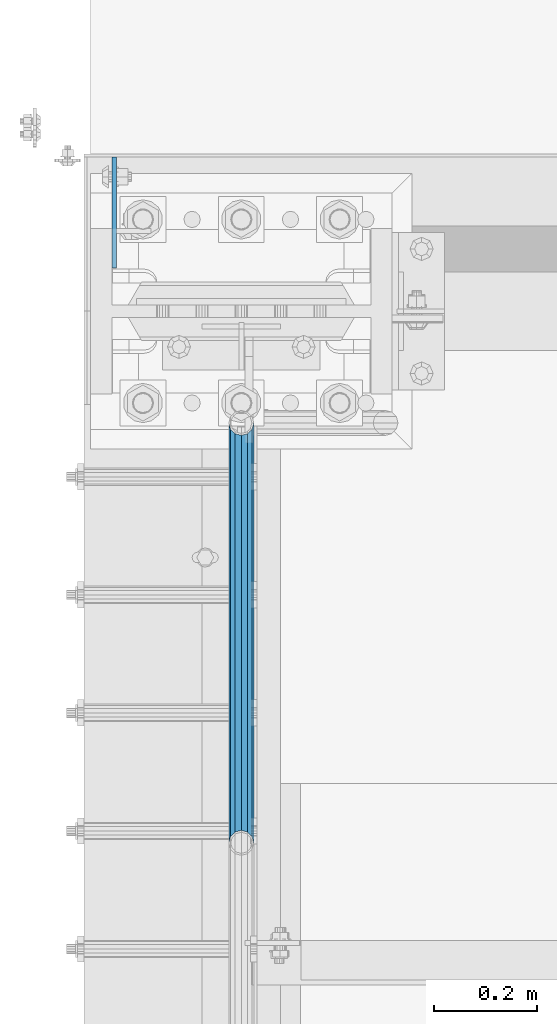
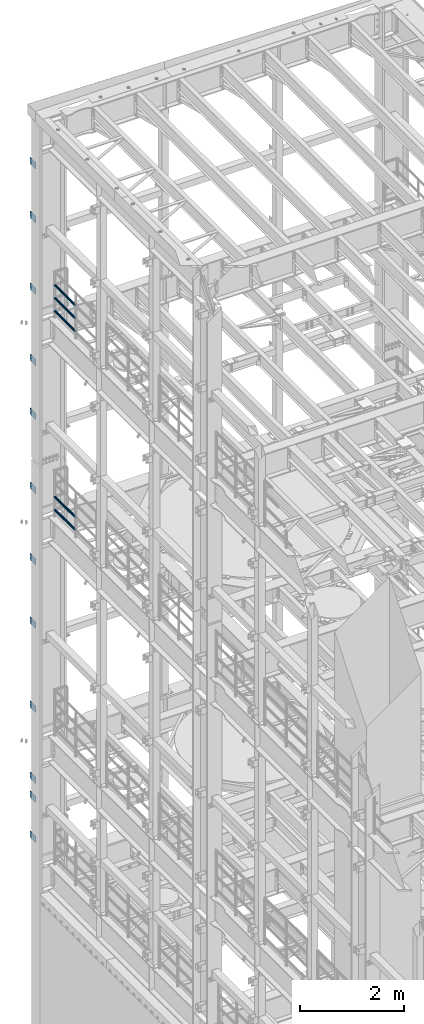
# One storey, part 1315 of 1876: 17 beams, 4 elements without a shape of their own.
"""IFC2X3 building model written with IfcOpenShell, lengths in millimetres."""

from ifc_helpers import new_model, si_unit, frame, origin_with_axes, place, context, subcontext, project, spatial, faceted_brep, material, type_object, element, aggregate, save


model = new_model("IFC2X3")

# Units and contexts
model_context = context("Model", 3, precision=1e-05, world=origin_with_axes())
body_context = subcontext(model_context, "Body", "Model", "MODEL_VIEW")
ifc_project = project(units=[si_unit("LENGTHUNIT", "METRE", prefix="MILLI"), si_unit("AREAUNIT", "SQUARE_METRE"), si_unit("VOLUMEUNIT", "CUBIC_METRE"), si_unit("MASSUNIT", "GRAM", prefix="KILO"), si_unit("TIMEUNIT", "SECOND"), si_unit("PLANEANGLEUNIT", "RADIAN"), si_unit("SOLIDANGLEUNIT", "STERADIAN"), si_unit("THERMODYNAMICTEMPERATUREUNIT", "DEGREE_CELSIUS"), si_unit("LUMINOUSINTENSITYUNIT", "LUMEN")], contexts=[model_context])

# Site, building, storey
site_placement = place(None, origin_with_axes())
site = spatial("IfcSite", under=ifc_project, at=site_placement, CompositionType="ELEMENT")
building_placement = place(site_placement, origin_with_axes())
building = spatial("IfcBuilding", under=site, at=building_placement, Name="Undefined", CompositionType="ELEMENT")
storey_placement = place(building_placement, origin_with_axes())
storey = spatial("IfcBuildingStorey", under=building, at=storey_placement, Name="Undefined", CompositionType="ELEMENT", Elevation=0.0)

# Assembly, beams
assembly_1_placement = place(storey_placement, origin_with_axes())
assembly_1 = element("IfcElementAssembly", 1, at=assembly_1_placement, inside=storey, Name="COLUMN", AssemblyPlace="NOTDEFINED", PredefinedType="RIGID_FRAME")
ifc_material_1 = material(Name="STEEL/A36")
beam_type_1 = type_object("IfcBeamType", PredefinedType="NOTDEFINED")
beam_1_placement = place(assembly_1_placement, frame((-246.0625, 13800.1375001356, 21450.3), z_axis=(0.0, 0.0, -1.0), x_axis=(0.0, 1.0, 0.0)))
beam_1 = element("IfcBeam", 2, at=beam_1_placement, type_object=beam_type_1, material=ifc_material_1, Name="PLATE", context=body_context, shape_type="Brep", body=[
    faceted_brep([(0.0, 4.76249999999982, -76.1999999999998), (3.63797880709171e-12, 4.76249999999982, 76.1999969482422), (214.312499998445, 4.76249999993797, 76.2000000000007), (214.312499998445, 4.76249999993797, -76.2000000000007), (3.63797880709171e-12, -4.76249999999982, 76.1999969482422), (214.312499998441, -4.76250000006257, 76.2000000000007), (0.0, -4.76249999999982, -76.1999999999998), (214.312499998441, -4.76250000006257, -76.2000000000007)], [[[0, 1, 2, 3]], [[1, 4, 5, 2]], [[4, 6, 7, 5]], [[6, 0, 3, 7]], [[5, 7, 3, 2]], [[6, 4, 1, 0]]]),
])
beam_2_placement = place(assembly_1_placement, frame((-246.0625, 13800.1375001356, 20186.65), z_axis=(0.0, 0.0, -1.0), x_axis=(0.0, 1.0, 0.0)))
beam_2 = element("IfcBeam", 3, at=beam_2_placement, type_object=beam_type_1, material=ifc_material_1, Name="PLATE", context=body_context, shape_type="Brep", body=[
    faceted_brep([(0.0, 4.76249999999982, -76.1999999999998), (3.63797880709171e-12, 4.76249999999982, 76.1999969482422), (214.312499998445, 4.76249999993797, 76.2000000000007), (214.312499998445, 4.76249999993797, -76.2000000000007), (3.63797880709171e-12, -4.76249999999982, 76.1999969482422), (214.312499998441, -4.76250000006257, 76.2000000000007), (0.0, -4.76249999999982, -76.1999999999998), (214.312499998441, -4.76250000006257, -76.2000000000007)], [[[0, 1, 2, 3]], [[1, 4, 5, 2]], [[4, 6, 7, 5]], [[6, 0, 3, 7]], [[5, 7, 3, 2]], [[6, 4, 1, 0]]]),
])
beam_3_placement = place(assembly_1_placement, frame((-246.0625, 13800.1375001356, 18503.9), z_axis=(0.0, 0.0, -1.0), x_axis=(0.0, 1.0, 0.0)))
beam_3 = element("IfcBeam", 4, at=beam_3_placement, type_object=beam_type_1, material=ifc_material_1, Name="PLATE", context=body_context, shape_type="Brep", body=[
    faceted_brep([(0.0, 4.76249999999982, -76.1999999999998), (3.63797880709171e-12, 4.76249999999982, 76.1999969482422), (214.312499998445, 4.76249999993797, 76.2000000000007), (214.312499998445, 4.76249999993797, -76.2000000000007), (3.63797880709171e-12, -4.76249999999982, 76.1999969482422), (214.312499998441, -4.76250000006257, 76.2000000000007), (0.0, -4.76249999999982, -76.1999999999998), (214.312499998441, -4.76250000006257, -76.2000000000007)], [[[0, 1, 2, 3]], [[1, 4, 5, 2]], [[4, 6, 7, 5]], [[6, 0, 3, 7]], [[5, 7, 3, 2]], [[6, 4, 1, 0]]]),
])
beam_4_placement = place(assembly_1_placement, frame((-246.0625, 13800.1375001356, 16827.5), z_axis=(0.0, 0.0, -1.0), x_axis=(0.0, 1.0, 0.0)))
beam_4 = element("IfcBeam", 5, at=beam_4_placement, type_object=beam_type_1, material=ifc_material_1, Name="PLATE", context=body_context, shape_type="Brep", body=[
    faceted_brep([(0.0, 4.76249999999982, -76.1999999999998), (3.63797880709171e-12, 4.76249999999982, 76.1999969482422), (214.312499998445, 4.76249999993797, 76.2000000000007), (214.312499998445, 4.76249999993797, -76.2000000000007), (3.63797880709171e-12, -4.76249999999982, 76.1999969482422), (214.312499998441, -4.76250000006257, 76.2000000000007), (0.0, -4.76249999999982, -76.1999999999998), (214.312499998441, -4.76250000006257, -76.2000000000007)], [[[0, 1, 2, 3]], [[1, 4, 5, 2]], [[4, 6, 7, 5]], [[6, 0, 3, 7]], [[5, 7, 3, 2]], [[6, 4, 1, 0]]]),
])
beam_5_placement = place(assembly_1_placement, frame((-246.0625, 13800.1375001356, 15563.85), z_axis=(0.0, 0.0, -1.0), x_axis=(0.0, 1.0, 0.0)))
beam_5 = element("IfcBeam", 6, at=beam_5_placement, type_object=beam_type_1, material=ifc_material_1, Name="PLATE", context=body_context, shape_type="Brep", body=[
    faceted_brep([(0.0, 4.76249999999982, -76.1999999999998), (3.63797880709171e-12, 4.76249999999982, 76.1999969482422), (214.312499998445, 4.76249999993797, 76.2000000000007), (214.312499998445, 4.76249999993797, -76.2000000000007), (3.63797880709171e-12, -4.76249999999982, 76.1999969482422), (214.312499998441, -4.76250000006257, 76.2000000000007), (0.0, -4.76249999999982, -76.1999999999998), (214.312499998441, -4.76250000006257, -76.2000000000007)], [[[0, 1, 2, 3]], [[1, 4, 5, 2]], [[4, 6, 7, 5]], [[6, 0, 3, 7]], [[5, 7, 3, 2]], [[6, 4, 1, 0]]]),
])
aggregate(assembly_1, [beam_1, beam_2, beam_3, beam_4, beam_5])

assembly_2_placement = place(storey_placement, origin_with_axes())
assembly_2 = element("IfcElementAssembly", 7, at=assembly_2_placement, inside=storey, Name="COLUMN", AssemblyPlace="NOTDEFINED", PredefinedType="RIGID_FRAME")
beam_6_placement = place(assembly_2_placement, frame((-246.0625, 13800.1375001356, 13817.6), z_axis=(0.0, 0.0, -1.0), x_axis=(0.0, 1.0, 0.0)))
beam_6 = element("IfcBeam", 8, at=beam_6_placement, type_object=beam_type_1, material=ifc_material_1, Name="PLATE", context=body_context, shape_type="Brep", body=[
    faceted_brep([(0.0, 4.76249999999982, -76.1999999999998), (3.63797880709171e-12, 4.76249999999982, 76.1999969482422), (214.312499998445, 4.76249999993797, 76.2000000000007), (214.312499998445, 4.76249999993797, -76.2000000000007), (3.63797880709171e-12, -4.76249999999982, 76.1999969482422), (214.312499998441, -4.76250000006257, 76.2000000000007), (0.0, -4.76249999999982, -76.1999999999998), (214.312499998441, -4.76250000006257, -76.2000000000007)], [[[0, 1, 2, 3]], [[1, 4, 5, 2]], [[4, 6, 7, 5]], [[6, 0, 3, 7]], [[5, 7, 3, 2]], [[6, 4, 1, 0]]]),
])
beam_7_placement = place(assembly_2_placement, frame((-246.0625, 13800.1375001356, 12141.2), z_axis=(0.0, 0.0, -1.0), x_axis=(0.0, 1.0, 0.0)))
beam_7 = element("IfcBeam", 9, at=beam_7_placement, type_object=beam_type_1, material=ifc_material_1, Name="PLATE", context=body_context, shape_type="Brep", body=[
    faceted_brep([(0.0, 4.76249999999982, -76.1999999999998), (3.63797880709171e-12, 4.76249999999982, 76.1999969482422), (214.312499998445, 4.76249999993797, 76.2000000000007), (214.312499998445, 4.76249999993797, -76.2000000000007), (3.63797880709171e-12, -4.76249999999982, 76.1999969482422), (214.312499998441, -4.76250000006257, 76.2000000000007), (0.0, -4.76249999999982, -76.1999999999998), (214.312499998441, -4.76250000006257, -76.2000000000007)], [[[0, 1, 2, 3]], [[1, 4, 5, 2]], [[4, 6, 7, 5]], [[6, 0, 3, 7]], [[5, 7, 3, 2]], [[6, 4, 1, 0]]]),
])
beam_8_placement = place(assembly_2_placement, frame((-246.0625, 13800.1375001356, 10648.95), z_axis=(0.0, 0.0, -1.0), x_axis=(0.0, 1.0, 0.0)))
beam_8 = element("IfcBeam", 10, at=beam_8_placement, type_object=beam_type_1, material=ifc_material_1, Name="PLATE", context=body_context, shape_type="Brep", body=[
    faceted_brep([(0.0, 4.76249999999982, -76.1999999999998), (3.63797880709171e-12, 4.76249999999982, 76.1999969482422), (214.312499998445, 4.76249999993797, 76.2000000000007), (214.312499998445, 4.76249999993797, -76.2000000000007), (3.63797880709171e-12, -4.76249999999982, 76.1999969482422), (214.312499998441, -4.76250000006257, 76.2000000000007), (0.0, -4.76249999999982, -76.1999999999998), (214.312499998441, -4.76250000006257, -76.2000000000007)], [[[0, 1, 2, 3]], [[1, 4, 5, 2]], [[4, 6, 7, 5]], [[6, 0, 3, 7]], [[5, 7, 3, 2]], [[6, 4, 1, 0]]]),
])
beam_9_placement = place(assembly_2_placement, frame((-246.0625, 13800.1375001356, 8674.1), z_axis=(0.0, 0.0, -1.0), x_axis=(0.0, 1.0, 0.0)))
beam_9 = element("IfcBeam", 11, at=beam_9_placement, type_object=beam_type_1, material=ifc_material_1, Name="PLATE", context=body_context, shape_type="Brep", body=[
    faceted_brep([(0.0, 4.76249999999982, -76.1999999999998), (3.63797880709171e-12, 4.76249999999982, 76.1999969482422), (214.312499998445, 4.76249999993797, 76.2000000000007), (214.312499998445, 4.76249999993797, -76.2000000000007), (3.63797880709171e-12, -4.76249999999982, 76.1999969482422), (214.312499998441, -4.76250000006257, 76.2000000000007), (0.0, -4.76249999999982, -76.1999999999998), (214.312499998441, -4.76250000006257, -76.2000000000007)], [[[0, 1, 2, 3]], [[1, 4, 5, 2]], [[4, 6, 7, 5]], [[6, 0, 3, 7]], [[5, 7, 3, 2]], [[6, 4, 1, 0]]]),
])
beam_10_placement = place(assembly_2_placement, frame((-246.0625, 13800.1375001356, 6997.7), z_axis=(0.0, 0.0, -1.0), x_axis=(0.0, 1.0, 0.0)))
beam_10 = element("IfcBeam", 12, at=beam_10_placement, type_object=beam_type_1, material=ifc_material_1, Name="PLATE", context=body_context, shape_type="Brep", body=[
    faceted_brep([(0.0, 4.76249999999982, -76.1999999999998), (3.63797880709171e-12, 4.76249999999982, 76.1999969482422), (214.312499998445, 4.76249999993797, 76.2000000000007), (214.312499998445, 4.76249999993797, -76.2000000000007), (3.63797880709171e-12, -4.76249999999982, 76.1999969482422), (214.312499998441, -4.76250000006257, 76.2000000000007), (0.0, -4.76249999999982, -76.1999999999998), (214.312499998441, -4.76250000006257, -76.2000000000007)], [[[0, 1, 2, 3]], [[1, 4, 5, 2]], [[4, 6, 7, 5]], [[6, 0, 3, 7]], [[5, 7, 3, 2]], [[6, 4, 1, 0]]]),
])
beam_11_placement = place(assembly_2_placement, frame((-246.0625, 13800.1375001356, 6559.55), z_axis=(0.0, 0.0, -1.0), x_axis=(0.0, 1.0, 0.0)))
beam_11 = element("IfcBeam", 13, at=beam_11_placement, type_object=beam_type_1, material=ifc_material_1, Name="PLATE", context=body_context, shape_type="Brep", body=[
    faceted_brep([(0.0, 4.76249999999982, -76.1999999999998), (3.63797880709171e-12, 4.76249999999982, 76.1999969482422), (214.312499998445, 4.76249999993797, 76.2000000000007), (214.312499998445, 4.76249999993797, -76.2000000000007), (3.63797880709171e-12, -4.76249999999982, 76.1999969482422), (214.312499998441, -4.76250000006257, 76.2000000000007), (0.0, -4.76249999999982, -76.1999999999998), (214.312499998441, -4.76250000006257, -76.2000000000007)], [[[0, 1, 2, 3]], [[1, 4, 5, 2]], [[4, 6, 7, 5]], [[6, 0, 3, 7]], [[5, 7, 3, 2]], [[6, 4, 1, 0]]]),
])
beam_12_placement = place(assembly_2_placement, frame((-246.0625, 13800.1375001356, 5613.4), z_axis=(0.0, 0.0, -1.0), x_axis=(0.0, 1.0, 0.0)))
beam_12 = element("IfcBeam", 14, at=beam_12_placement, type_object=beam_type_1, material=ifc_material_1, Name="PLATE", context=body_context, shape_type="Brep", body=[
    faceted_brep([(0.0, 4.76249999999982, -76.1999999999998), (3.63797880709171e-12, 4.76249999999982, 76.1999969482422), (214.312499998445, 4.76249999993797, 76.2000000000007), (214.312499998445, 4.76249999993797, -76.2000000000007), (3.63797880709171e-12, -4.76249999999982, 76.1999969482422), (214.312499998441, -4.76250000006257, 76.2000000000007), (0.0, -4.76249999999982, -76.1999999999998), (214.312499998441, -4.76250000006257, -76.2000000000007)], [[[0, 1, 2, 3]], [[1, 4, 5, 2]], [[4, 6, 7, 5]], [[6, 0, 3, 7]], [[5, 7, 3, 2]], [[6, 4, 1, 0]]]),
])
aggregate(assembly_2, [beam_6, beam_7, beam_8, beam_9, beam_10, beam_11, beam_12])

assembly_3_placement = place(storey_placement, origin_with_axes())
assembly_3 = element("IfcElementAssembly", 15, at=assembly_3_placement, inside=storey, Name="RAIL", AssemblyPlace="NOTDEFINED", PredefinedType="RIGID_FRAME")
ifc_material_2 = material()
beam_type_2 = type_object("IfcBeamType", Name="PIPE1-1/2SCH40", PredefinedType="NOTDEFINED")
beam_13_placement = place(assembly_3_placement, frame((1.81311423431267e-11, 13499.7063, 18145.125), z_axis=(0.0, 0.0, 1.0), x_axis=(0.0, -1.0, 0.0)))
beam_13 = element("IfcBeam", 16, at=beam_13_placement, type_object=beam_type_2, material=ifc_material_2, Name="RAIL", ObjectType="PIPE1-1/2SCH40", context=body_context, shape_type="Brep", body=[
    faceted_brep([(792.499707006684, -12.0649999999996, 20.8971929933177), (792.499707006684, -12.0650000000314, 15.8661214311469), (792.006278568813, -10.2235000000001, 17.7076214311819), (789.266900000001, -9.09494701772928e-13, 20.4470000000001), (789.266900000001, -9.09494701772928e-13, 24.130000000001), (792.00627856883, 10.2235000000001, 17.7076214311819), (792.499707006684, 12.0649999999678, 15.8661214312124), (792.499707006684, 12.0649999999996, 20.8971929933177), (813.396900000002, 24.1300000000001, 0.0), (801.331900000001, 20.8971929933186, 12.0649999999987), (801.331900000001, 20.8971929933186, -12.0649999999987), (798.142328437896, 17.7076214311801, 10.2235000000001), (800.881707006714, 20.4470000000001, 0.0), (798.142328437896, 17.7076214311801, -10.2235000000001), (792.499707006684, 12.0649999999678, -15.8661214312124), (792.499707006684, 12.0649999999996, -20.8971929933177), (792.00627856883, 10.2235000000001, -17.7076214311819), (789.266900000001, 0.0, -20.4470000000001), (789.266900000001, 0.0, -24.130000000001), (792.499707006684, -12.0650000000314, -15.8661214311469), (792.499707006684, -12.0649999999996, -20.8971929933177), (792.006278568813, -10.2235000000001, -17.7076214311819), (813.396900000002, -24.1300000000319, 0.0), (801.331900000001, -20.8971929933186, -12.0649999999987), (801.331900000001, -20.8971929933186, 12.0649999999987), (798.142328437831, -17.7076214311801, -10.2235000000001), (800.881707006651, -20.4470000000001, 0.0), (798.142328437831, -17.7076214311801, 10.2235000000001), (12.0650000000064, -20.8971929933177, -12.0649999999987), (20.8971929933249, -12.0650000000005, -20.8971929933177), (0.0, 24.1299999999992, 0.0), (12.0650000000064, 20.8971929933177, -12.0649999999987), (12.0650000000064, 20.8971929933177, 12.0649999999987), (20.8971929933249, 12.0650000000005, 20.8971929933177), (24.1300000000064, 0.0, 24.130000000001), (20.8971929933249, 12.0650000000005, -20.8971929933177), (24.1300000000063, 0.0, -24.130000000001), (24.1300000000063, 0.0, -20.4470000000001), (20.8971929933249, -12.0650000000005, -15.8661214311796), (21.3906214311868, -10.2235000000001, -17.7076214311819), (21.3906214311868, 10.2235000000001, -17.7076214311819), (20.8971929933249, 12.0650000000005, -15.8661214311796), (15.2545715621445, 17.7076214311801, -10.2235000000001), (12.5151929933249, 20.4470000000001, 0.0), (15.2545715621445, 17.7076214311801, 10.2235000000001), (20.8971929933249, 12.0650000000005, 15.8661214311796), (21.3906214311868, 10.2235000000001, 17.7076214311819), (24.1300000000064, 0.0, 20.4470000000001), (21.3906214311868, -10.2235000000001, 17.7076214311819), (20.8971929933249, -12.0650000000005, 15.8661214311796), (20.8971929933249, -12.0650000000005, 20.8971929933177), (12.0650000000064, -20.8971929933177, 12.0649999999987), (0.0, -24.1299999999992, 0.0), (15.2545715621445, -17.7076214311801, 10.2235000000001), (12.5151929933249, -20.4470000000001, 0.0), (15.2545715621445, -17.7076214311801, -10.2235000000001)], [[[0, 1, 2, 3, 4]], [[4, 3, 5, 6, 7]], [[8, 9, 10]], [[7, 6, 11, 12, 13, 14, 15, 10, 9]], [[16, 17, 18, 15, 14]], [[19, 20, 18, 17, 21]], [[22, 23, 24]], [[24, 23, 20, 19, 25, 26, 27, 1, 0]], [[28, 29, 20, 23]], [[30, 31, 32]], [[33, 34, 4, 7]], [[32, 33, 7, 9]], [[30, 32, 9, 8]], [[31, 30, 8, 10]], [[35, 31, 10, 15]], [[36, 35, 15, 18]], [[29, 36, 18, 20]], [[37, 36, 29, 38, 39]], [[40, 41, 35, 36, 37]], [[32, 31, 35, 41, 42, 43, 44, 45, 33]], [[33, 45, 46, 47, 34]], [[34, 47, 48, 49, 50]], [[34, 50, 0, 4]], [[50, 51, 24, 0]], [[51, 52, 22, 24]], [[52, 28, 23, 22]], [[51, 28, 52]], [[50, 49, 53, 54, 55, 38, 29, 28, 51]], [[55, 54, 26, 25]], [[21, 39, 38, 55, 25, 19]], [[37, 39, 21, 17]], [[40, 37, 17, 16]], [[42, 41, 40, 16, 14, 13]], [[43, 42, 13, 12]], [[44, 43, 12, 11]], [[5, 46, 45, 44, 11, 6]], [[47, 46, 5, 3]], [[48, 47, 3, 2]], [[53, 49, 48, 2, 1, 27]], [[54, 53, 27, 26]]]),
])
beam_14_placement = place(assembly_3_placement, frame((-1.81898940354586e-12, 12686.3094, 18449.925), z_axis=(0.0, 0.0, -1.0), x_axis=(0.0, 1.0, 0.0)))
beam_14 = element("IfcBeam", 17, at=beam_14_placement, type_object=beam_type_2, material=ifc_material_2, Name="RAIL", ObjectType="PIPE1-1/2SCH40", context=body_context, shape_type="Brep", body=[
    faceted_brep([(0.0, 24.1299999999992, 0.0), (12.0650000000064, 20.8971929933177, -12.0649999999987), (12.0650000000064, 20.8971929933177, 12.0649999999987), (12.0650000000064, -20.8971929933177, 12.0649999999987), (12.0650000000064, -20.8971929933177, -12.0649999999987), (0.0, -24.1299999999992, 0.0), (20.8971929933249, -12.0650000000005, 20.8971929933177), (20.8971929933249, -12.0650000000005, 15.8661214311796), (15.2545715621445, -17.7076214311801, 10.2235000000001), (12.5151929933249, -20.4470000000001, 0.0), (15.2545715621445, -17.7076214311801, -10.2235000000001), (20.8971929933249, -12.0650000000005, -15.8661214311796), (20.8971929933249, -12.0650000000005, -20.8971929933177), (24.1300000000063, 0.0, -20.4470000000001), (24.1300000000063, 0.0, -24.130000000001), (21.3906214311868, -10.2235000000001, -17.7076214311819), (21.3906214311868, 10.2235000000001, -17.7076214311819), (20.8971929933249, 12.0650000000005, -15.8661214311796), (20.8971929933249, 12.0650000000005, -20.8971929933177), (15.2545715621445, 17.7076214311801, -10.2235000000001), (12.5151929933249, 20.4470000000001, 0.0), (15.2545715621445, 17.7076214311801, 10.2235000000001), (20.8971929933249, 12.0650000000005, 15.8661214311796), (20.8971929933249, 12.0650000000005, 20.8971929933177), (21.3906214311868, 10.2235000000001, 17.7076214311819), (24.1300000000064, 0.0, 20.4470000000001), (24.1300000000064, 0.0, 24.130000000001), (21.3906214311868, -10.2235000000001, 17.7076214311819), (813.396900000002, 24.1300000000001, 0.0), (801.331900000001, 20.8971929933186, -12.0649999999987), (792.499707006684, 12.0649999999996, -20.8971929933177), (813.396900000002, -24.1300000000319, 0.0), (801.331900000001, -20.8971929933186, -12.0649999999987), (801.331900000001, -20.8971929933186, 12.0649999999987), (792.499707006684, -12.0649999999996, 20.8971929933177), (792.499707006684, -12.0649999999996, -20.8971929933177), (789.266900000001, 0.0, -24.130000000001), (792.00627856883, 10.2235000000001, -17.7076214311819), (789.266900000001, 0.0, -20.4470000000001), (792.499707006684, 12.0649999999678, -15.8661214312124), (792.499707006684, -12.0650000000314, -15.8661214311469), (792.006278568813, -10.2235000000001, -17.7076214311819), (798.142328437831, -17.7076214311801, -10.2235000000001), (800.881707006651, -20.4470000000001, 0.0), (798.142328437831, -17.7076214311801, 10.2235000000001), (792.499707006684, -12.0650000000314, 15.8661214311469), (792.006278568813, -10.2235000000001, 17.7076214311819), (789.266900000001, -9.09494701772928e-13, 20.4470000000001), (789.266900000001, -9.09494701772928e-13, 24.130000000001), (792.499707006684, 12.0649999999996, 20.8971929933177), (801.331900000001, 20.8971929933186, 12.0649999999987), (792.499707006684, 12.0649999999678, 15.8661214312124), (798.142328437896, 17.7076214311801, 10.2235000000001), (800.881707006714, 20.4470000000001, 0.0), (798.142328437896, 17.7076214311801, -10.2235000000001), (792.00627856883, 10.2235000000001, 17.7076214311819)], [[[0, 1, 2]], [[3, 4, 5]], [[6, 7, 8, 9, 10, 11, 12, 4, 3]], [[13, 14, 12, 11, 15]], [[16, 17, 18, 14, 13]], [[2, 1, 18, 17, 19, 20, 21, 22, 23]], [[23, 22, 24, 25, 26]], [[26, 25, 27, 7, 6]], [[1, 0, 28, 29]], [[18, 1, 29, 30]], [[31, 32, 33]], [[6, 3, 33, 34]], [[3, 5, 31, 33]], [[5, 4, 32, 31]], [[4, 12, 35, 32]], [[12, 14, 36, 35]], [[14, 18, 30, 36]], [[37, 38, 36, 30, 39]], [[40, 35, 36, 38, 41]], [[33, 32, 35, 40, 42, 43, 44, 45, 34]], [[34, 45, 46, 47, 48]], [[26, 6, 34, 48]], [[2, 23, 49, 50]], [[23, 26, 48, 49]], [[0, 2, 50, 28]], [[28, 50, 29]], [[49, 51, 52, 53, 54, 39, 30, 29, 50]], [[48, 47, 55, 51, 49]], [[25, 24, 55, 47]], [[55, 24, 22, 21, 52, 51]], [[21, 20, 53, 52]], [[20, 19, 54, 53]], [[19, 17, 16, 37, 39, 54]], [[16, 13, 38, 37]], [[13, 15, 41, 38]], [[41, 15, 11, 10, 42, 40]], [[10, 9, 43, 42]], [[9, 8, 44, 43]], [[8, 7, 27, 46, 45, 44]], [[27, 25, 47, 46]]]),
])
beam_15_placement = place(assembly_3_placement, frame((-1.81898940354586e-12, 12686.3094, 18754.725), z_axis=(0.0, 0.0, -1.0), x_axis=(0.0, 1.0, 0.0)))
beam_15 = element("IfcBeam", 18, at=beam_15_placement, type_object=beam_type_2, material=ifc_material_2, Name="RAIL", ObjectType="PIPE1-1/2SCH40", context=body_context, shape_type="Brep", body=[
    faceted_brep([(0.0, 24.1299999999992, 0.0), (12.0650000000064, 20.8971929933177, -12.0649999999987), (12.0650000000064, 20.8971929933177, 12.0649999999987), (12.0650000000064, -20.8971929933177, 12.0649999999987), (12.0650000000064, -20.8971929933177, -12.0649999999987), (0.0, -24.1299999999992, 0.0), (20.8971929933249, -12.0650000000005, 20.8971929933177), (20.8971929933249, -12.0650000000005, 15.8661214311796), (15.2545715621445, -17.7076214311801, 10.2235000000001), (12.5151929933249, -20.4470000000001, 0.0), (15.2545715621445, -17.7076214311801, -10.2235000000001), (20.8971929933249, -12.0650000000005, -15.8661214311796), (20.8971929933249, -12.0650000000005, -20.8971929933177), (24.1300000000063, 0.0, -20.4470000000001), (24.1300000000063, 0.0, -24.130000000001), (21.3906214311868, -10.2235000000001, -17.7076214311819), (21.3906214311868, 10.2235000000001, -17.7076214311819), (20.8971929933249, 12.0650000000005, -15.8661214311796), (20.8971929933249, 12.0650000000005, -20.8971929933177), (15.2545715621445, 17.7076214311801, -10.2235000000001), (12.5151929933249, 20.4470000000001, 0.0), (15.2545715621445, 17.7076214311801, 10.2235000000001), (20.8971929933249, 12.0650000000005, 15.8661214311796), (20.8971929933249, 12.0650000000005, 20.8971929933177), (21.3906214311868, 10.2235000000001, 17.7076214311819), (24.1300000000064, 0.0, 20.4470000000001), (24.1300000000064, 0.0, 24.130000000001), (21.3906214311868, -10.2235000000001, 17.7076214311819), (813.396900000002, 24.1300000000001, 0.0), (801.331900000001, 20.8971929933186, -12.0649999999987), (792.499707006684, 12.0649999999996, -20.8971929933177), (813.396900000002, -24.1300000000319, 0.0), (801.331900000001, -20.8971929933186, -12.0649999999987), (801.331900000001, -20.8971929933186, 12.0649999999987), (792.499707006684, -12.0649999999996, 20.8971929933177), (792.499707006684, -12.0649999999996, -20.8971929933177), (789.266900000001, 0.0, -24.130000000001), (792.00627856883, 10.2235000000001, -17.7076214311819), (789.266900000001, 0.0, -20.4470000000001), (792.499707006684, 12.0649999999678, -15.8661214312124), (792.499707006684, -12.0650000000314, -15.8661214311469), (792.006278568813, -10.2235000000001, -17.7076214311819), (798.142328437831, -17.7076214311801, -10.2235000000001), (800.881707006651, -20.4470000000001, 0.0), (798.142328437831, -17.7076214311801, 10.2235000000001), (792.499707006684, -12.0650000000314, 15.8661214311469), (792.006278568813, -10.2235000000001, 17.7076214311819), (789.266900000001, -9.09494701772928e-13, 20.4470000000001), (789.266900000001, -9.09494701772928e-13, 24.130000000001), (792.499707006684, 12.0649999999996, 20.8971929933177), (801.331900000001, 20.8971929933186, 12.0649999999987), (792.499707006684, 12.0649999999678, 15.8661214312124), (798.142328437896, 17.7076214311801, 10.2235000000001), (800.881707006714, 20.4470000000001, 0.0), (798.142328437896, 17.7076214311801, -10.2235000000001), (792.00627856883, 10.2235000000001, 17.7076214311819)], [[[0, 1, 2]], [[3, 4, 5]], [[6, 7, 8, 9, 10, 11, 12, 4, 3]], [[13, 14, 12, 11, 15]], [[16, 17, 18, 14, 13]], [[2, 1, 18, 17, 19, 20, 21, 22, 23]], [[23, 22, 24, 25, 26]], [[26, 25, 27, 7, 6]], [[1, 0, 28, 29]], [[18, 1, 29, 30]], [[31, 32, 33]], [[6, 3, 33, 34]], [[3, 5, 31, 33]], [[5, 4, 32, 31]], [[4, 12, 35, 32]], [[12, 14, 36, 35]], [[14, 18, 30, 36]], [[37, 38, 36, 30, 39]], [[40, 35, 36, 38, 41]], [[33, 32, 35, 40, 42, 43, 44, 45, 34]], [[34, 45, 46, 47, 48]], [[26, 6, 34, 48]], [[2, 23, 49, 50]], [[23, 26, 48, 49]], [[0, 2, 50, 28]], [[28, 50, 29]], [[49, 51, 52, 53, 54, 39, 30, 29, 50]], [[48, 47, 55, 51, 49]], [[25, 24, 55, 47]], [[55, 24, 22, 21, 52, 51]], [[21, 20, 53, 52]], [[20, 19, 54, 53]], [[19, 17, 16, 37, 39, 54]], [[16, 13, 38, 37]], [[13, 15, 41, 38]], [[41, 15, 11, 10, 42, 40]], [[10, 9, 43, 42]], [[9, 8, 44, 43]], [[8, 7, 27, 46, 45, 44]], [[27, 25, 47, 46]]]),
])
aggregate(assembly_3, [beam_13, beam_14, beam_15])

assembly_4_placement = place(storey_placement, origin_with_axes())
assembly_4 = element("IfcElementAssembly", 19, at=assembly_4_placement, inside=storey, Name="RAIL", AssemblyPlace="NOTDEFINED", PredefinedType="RIGID_FRAME")
beam_16_placement = place(assembly_4_placement, frame((1.81311423431267e-11, 13499.7063, 13471.525), z_axis=(0.0, 0.0, 1.0), x_axis=(0.0, -1.0, 0.0)))
beam_16 = element("IfcBeam", 20, at=beam_16_placement, type_object=beam_type_2, material=ifc_material_2, Name="RAIL", ObjectType="PIPE1-1/2SCH40", context=body_context, shape_type="Brep", body=[
    faceted_brep([(792.499707006684, -12.0649999999996, 20.8971929933177), (792.499707006684, -12.0650000000314, 15.8661214311469), (792.006278568813, -10.2235000000001, 17.7076214311819), (789.266900000001, -9.09494701772928e-13, 20.4470000000001), (789.266900000001, -9.09494701772928e-13, 24.130000000001), (792.00627856883, 10.2235000000001, 17.7076214311819), (792.499707006684, 12.0649999999678, 15.8661214312124), (792.499707006684, 12.0649999999996, 20.8971929933177), (813.396900000002, 24.1300000000001, 0.0), (801.331900000001, 20.8971929933186, 12.0649999999987), (801.331900000001, 20.8971929933186, -12.0649999999987), (798.142328437896, 17.7076214311801, 10.2235000000001), (800.881707006714, 20.4470000000001, 0.0), (798.142328437896, 17.7076214311801, -10.2235000000001), (792.499707006684, 12.0649999999678, -15.8661214312124), (792.499707006684, 12.0649999999996, -20.8971929933177), (792.00627856883, 10.2235000000001, -17.7076214311819), (789.266900000001, 0.0, -20.4470000000001), (789.266900000001, 0.0, -24.130000000001), (792.499707006684, -12.0650000000314, -15.8661214311469), (792.499707006684, -12.0649999999996, -20.8971929933177), (792.006278568813, -10.2235000000001, -17.7076214311819), (813.396900000002, -24.1300000000319, 0.0), (801.331900000001, -20.8971929933186, -12.0649999999987), (801.331900000001, -20.8971929933186, 12.0649999999987), (798.142328437831, -17.7076214311801, -10.2235000000001), (800.881707006651, -20.4470000000001, 0.0), (798.142328437831, -17.7076214311801, 10.2235000000001), (12.0650000000064, -20.8971929933177, -12.0649999999987), (20.8971929933249, -12.0650000000005, -20.8971929933177), (0.0, 24.1299999999992, 0.0), (12.0650000000064, 20.8971929933177, -12.0649999999987), (12.0650000000064, 20.8971929933177, 12.0649999999987), (20.8971929933249, 12.0650000000005, 20.8971929933177), (24.1300000000064, 0.0, 24.130000000001), (20.8971929933249, 12.0650000000005, -20.8971929933177), (24.1300000000063, 0.0, -24.130000000001), (24.1300000000063, 0.0, -20.4470000000001), (20.8971929933249, -12.0650000000005, -15.8661214311796), (21.3906214311868, -10.2235000000001, -17.7076214311819), (21.3906214311868, 10.2235000000001, -17.7076214311819), (20.8971929933249, 12.0650000000005, -15.8661214311796), (15.2545715621445, 17.7076214311801, -10.2235000000001), (12.5151929933249, 20.4470000000001, 0.0), (15.2545715621445, 17.7076214311801, 10.2235000000001), (20.8971929933249, 12.0650000000005, 15.8661214311796), (21.3906214311868, 10.2235000000001, 17.7076214311819), (24.1300000000064, 0.0, 20.4470000000001), (21.3906214311868, -10.2235000000001, 17.7076214311819), (20.8971929933249, -12.0650000000005, 15.8661214311796), (20.8971929933249, -12.0650000000005, 20.8971929933177), (12.0650000000064, -20.8971929933177, 12.0649999999987), (0.0, -24.1299999999992, 0.0), (15.2545715621445, -17.7076214311801, 10.2235000000001), (12.5151929933249, -20.4470000000001, 0.0), (15.2545715621445, -17.7076214311801, -10.2235000000001)], [[[0, 1, 2, 3, 4]], [[4, 3, 5, 6, 7]], [[8, 9, 10]], [[7, 6, 11, 12, 13, 14, 15, 10, 9]], [[16, 17, 18, 15, 14]], [[19, 20, 18, 17, 21]], [[22, 23, 24]], [[24, 23, 20, 19, 25, 26, 27, 1, 0]], [[28, 29, 20, 23]], [[30, 31, 32]], [[33, 34, 4, 7]], [[32, 33, 7, 9]], [[30, 32, 9, 8]], [[31, 30, 8, 10]], [[35, 31, 10, 15]], [[36, 35, 15, 18]], [[29, 36, 18, 20]], [[37, 36, 29, 38, 39]], [[40, 41, 35, 36, 37]], [[32, 31, 35, 41, 42, 43, 44, 45, 33]], [[33, 45, 46, 47, 34]], [[34, 47, 48, 49, 50]], [[34, 50, 0, 4]], [[50, 51, 24, 0]], [[51, 52, 22, 24]], [[52, 28, 23, 22]], [[51, 28, 52]], [[50, 49, 53, 54, 55, 38, 29, 28, 51]], [[55, 54, 26, 25]], [[21, 39, 38, 55, 25, 19]], [[37, 39, 21, 17]], [[40, 37, 17, 16]], [[42, 41, 40, 16, 14, 13]], [[43, 42, 13, 12]], [[44, 43, 12, 11]], [[5, 46, 45, 44, 11, 6]], [[47, 46, 5, 3]], [[48, 47, 3, 2]], [[53, 49, 48, 2, 1, 27]], [[54, 53, 27, 26]]]),
])
beam_17_placement = place(assembly_4_placement, frame((-1.81898940354586e-12, 12686.3094, 13776.325), z_axis=(0.0, 0.0, -1.0), x_axis=(0.0, 1.0, 0.0)))
beam_17 = element("IfcBeam", 21, at=beam_17_placement, type_object=beam_type_2, material=ifc_material_2, Name="RAIL", ObjectType="PIPE1-1/2SCH40", context=body_context, shape_type="Brep", body=[
    faceted_brep([(0.0, 24.1299999999992, 0.0), (12.0650000000064, 20.8971929933177, -12.0649999999987), (12.0650000000064, 20.8971929933177, 12.0649999999987), (12.0650000000064, -20.8971929933177, 12.0649999999987), (12.0650000000064, -20.8971929933177, -12.0649999999987), (0.0, -24.1299999999992, 0.0), (20.8971929933249, -12.0650000000005, 20.8971929933177), (20.8971929933249, -12.0650000000005, 15.8661214311796), (15.2545715621445, -17.7076214311801, 10.2235000000001), (12.5151929933249, -20.4470000000001, 0.0), (15.2545715621445, -17.7076214311801, -10.2235000000001), (20.8971929933249, -12.0650000000005, -15.8661214311796), (20.8971929933249, -12.0650000000005, -20.8971929933177), (24.1300000000063, 0.0, -20.4470000000001), (24.1300000000063, 0.0, -24.130000000001), (21.3906214311868, -10.2235000000001, -17.7076214311819), (21.3906214311868, 10.2235000000001, -17.7076214311819), (20.8971929933249, 12.0650000000005, -15.8661214311796), (20.8971929933249, 12.0650000000005, -20.8971929933177), (15.2545715621445, 17.7076214311801, -10.2235000000001), (12.5151929933249, 20.4470000000001, 0.0), (15.2545715621445, 17.7076214311801, 10.2235000000001), (20.8971929933249, 12.0650000000005, 15.8661214311796), (20.8971929933249, 12.0650000000005, 20.8971929933177), (21.3906214311868, 10.2235000000001, 17.7076214311819), (24.1300000000064, 0.0, 20.4470000000001), (24.1300000000064, 0.0, 24.130000000001), (21.3906214311868, -10.2235000000001, 17.7076214311819), (813.396900000002, 24.1300000000001, 0.0), (801.331900000001, 20.8971929933186, -12.0649999999987), (792.499707006684, 12.0649999999996, -20.8971929933177), (813.396900000002, -24.1300000000319, 0.0), (801.331900000001, -20.8971929933186, -12.0649999999987), (801.331900000001, -20.8971929933186, 12.0649999999987), (792.499707006684, -12.0649999999996, 20.8971929933177), (792.499707006684, -12.0649999999996, -20.8971929933177), (789.266900000001, 0.0, -24.130000000001), (792.00627856883, 10.2235000000001, -17.7076214311819), (789.266900000001, 0.0, -20.4470000000001), (792.499707006684, 12.0649999999678, -15.8661214312124), (792.499707006684, -12.0650000000314, -15.8661214311469), (792.006278568813, -10.2235000000001, -17.7076214311819), (798.142328437831, -17.7076214311801, -10.2235000000001), (800.881707006651, -20.4470000000001, 0.0), (798.142328437831, -17.7076214311801, 10.2235000000001), (792.499707006684, -12.0650000000314, 15.8661214311469), (792.006278568813, -10.2235000000001, 17.7076214311819), (789.266900000001, -9.09494701772928e-13, 20.4470000000001), (789.266900000001, -9.09494701772928e-13, 24.130000000001), (792.499707006684, 12.0649999999996, 20.8971929933177), (801.331900000001, 20.8971929933186, 12.0649999999987), (792.499707006684, 12.0649999999678, 15.8661214312124), (798.142328437896, 17.7076214311801, 10.2235000000001), (800.881707006714, 20.4470000000001, 0.0), (798.142328437896, 17.7076214311801, -10.2235000000001), (792.00627856883, 10.2235000000001, 17.7076214311819)], [[[0, 1, 2]], [[3, 4, 5]], [[6, 7, 8, 9, 10, 11, 12, 4, 3]], [[13, 14, 12, 11, 15]], [[16, 17, 18, 14, 13]], [[2, 1, 18, 17, 19, 20, 21, 22, 23]], [[23, 22, 24, 25, 26]], [[26, 25, 27, 7, 6]], [[1, 0, 28, 29]], [[18, 1, 29, 30]], [[31, 32, 33]], [[6, 3, 33, 34]], [[3, 5, 31, 33]], [[5, 4, 32, 31]], [[4, 12, 35, 32]], [[12, 14, 36, 35]], [[14, 18, 30, 36]], [[37, 38, 36, 30, 39]], [[40, 35, 36, 38, 41]], [[33, 32, 35, 40, 42, 43, 44, 45, 34]], [[34, 45, 46, 47, 48]], [[26, 6, 34, 48]], [[2, 23, 49, 50]], [[23, 26, 48, 49]], [[0, 2, 50, 28]], [[28, 50, 29]], [[49, 51, 52, 53, 54, 39, 30, 29, 50]], [[48, 47, 55, 51, 49]], [[25, 24, 55, 47]], [[55, 24, 22, 21, 52, 51]], [[21, 20, 53, 52]], [[20, 19, 54, 53]], [[19, 17, 16, 37, 39, 54]], [[16, 13, 38, 37]], [[13, 15, 41, 38]], [[41, 15, 11, 10, 42, 40]], [[10, 9, 43, 42]], [[9, 8, 44, 43]], [[8, 7, 27, 46, 45, 44]], [[27, 25, 47, 46]]]),
])
aggregate(assembly_4, [beam_16, beam_17])

save(model, "model.ifc")
